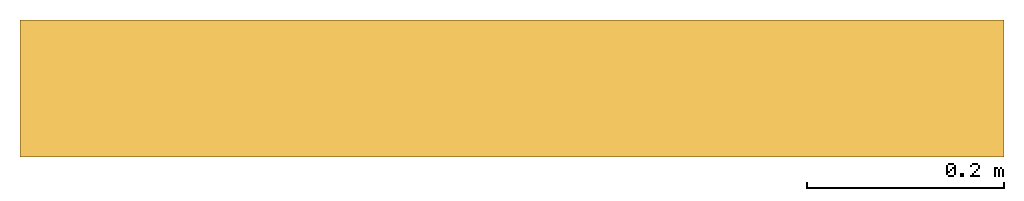
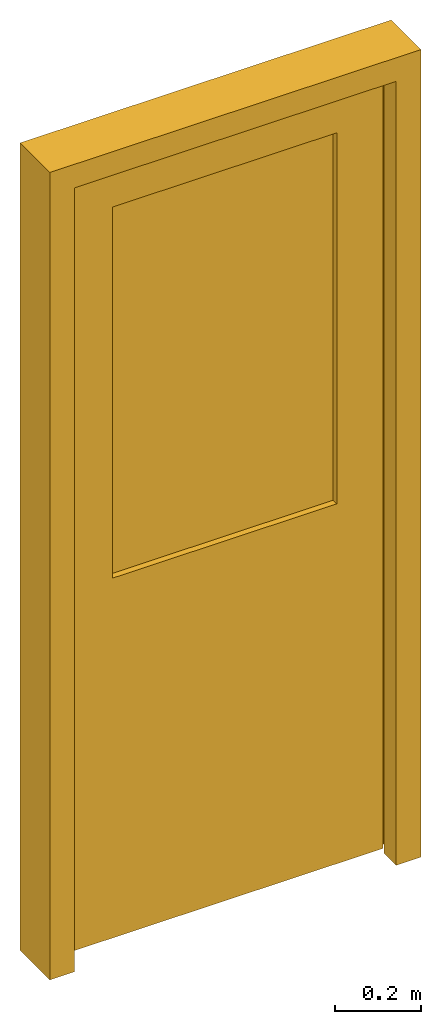
# One storey: 1 door.
"""IFC4 building model written with IfcOpenShell, lengths in millimetres."""

from ifc_helpers import new_model, entity, si_unit, converted_unit, frame, origin_with_axes, origin_2d_with_axis, place, context, subcontext, project, spatial, polygons, source, transform, mapped, type_object, type_shapes, element, save


model = new_model("IFC4")

# Units and contexts
model_context = context("Model", 3, precision=1e-05, world=origin_with_axes())
plan_context = context("Plan", 2, precision=1e-05, world=origin_2d_with_axis())
body_context = subcontext(model_context, "Body", "Model", "MODEL_VIEW")
ifc_project = project(units=[si_unit("VOLUMEUNIT", "CUBIC_METRE"), si_unit("LENGTHUNIT", "METRE", prefix="MILLI"), converted_unit("PLANEANGLEUNIT", "degree", entity("IfcReal", 0.0174532925199433), si_unit("PLANEANGLEUNIT", "RADIAN"), dimensions=[0, 0, 0, 0, 0, 0, 0]), si_unit("AREAUNIT", "SQUARE_METRE")], contexts=[model_context, plan_context])

# Site, building, storey
site_placement = place(None, origin_with_axes())
site = spatial("IfcSite", under=ifc_project, at=site_placement)
building_placement = place(site_placement, origin_with_axes())
building = spatial("IfcBuilding", under=site, at=building_placement, Name="Building")
storey_placement = place(building_placement, origin_with_axes())
storey = spatial("IfcBuildingStorey", under=building, at=storey_placement, Name="Storey")

# Door
door_type = type_object("IfcDoorType", Name="D-1000x2300", OperationType="NOTDEFINED", PredefinedType="DOOR")
shared_shape = source(origin_with_axes(), body_context, "Body", "Tessellation", [
    polygons([(0.0, 5.02680959471036e-05, 2.43237044004682e-13), (1000.00006103516, 5.02680959471036e-05, 2.43237044004682e-13), (0.0, -5.02680959471036e-05, 2300.0), (1000.00006103516, -5.02680959471036e-05, 2300.0), (67.0000305175781, -139.000076293945, 2233.00024414062), (67.0000305175781, -138.999954223633, -6.07588344792021e-06), (933.000061035156, -138.999954223633, -6.07588344792021e-06), (933.000061035156, -139.000076293945, 2233.00024414062), (0.0, -139.000076293945, 2300.0), (0.0, -138.999954223633, -6.07588344792021e-06), (1000.00006103516, -138.999954223633, -6.07588344792021e-06), (1000.00006103516, -139.000076293945, 2300.0), (933.000061035156, -82.0000457763672, 2233.00024414062), (67.0000305175781, -82.0000457763672, 2233.00024414062), (67.0000305175781, -82.0000457763672, -3.58433771907585e-06), (933.000061035156, -82.0000457763672, -3.58433771907585e-06), (49.9999504089355, 4.73394320579246e-05, 1.15221078663373e-13), (49.9999504089355, -82.0000457763672, -3.58433771907585e-06), (67.0000305175781, -4.73394320579246e-05, 2249.99975585938), (67.0000305175781, -82.0000457763672, 2249.99975585938), (49.9999504089355, -82.0000457763672, 2249.99975585938), (49.9999504089355, -4.73394320579246e-05, 2249.99975585938), (950.000061035156, 4.73394320579246e-05, 1.15221078663373e-13), (950.000061035156, -4.73394393338822e-05, 2233.00024414062), (950.000061035156, -82.0000457763672, 2249.99975585938), (950.000061035156, -82.0000457763672, 2233.00024414062), (950.000061035156, -82.0000457763672, -3.58433771907585e-06), (950.000061035156, -4.73394320579246e-05, 2249.99975585938), (198.000015258789, -34.9999504089355, 1045.0), (802.000061035156, -34.9999504089355, 1045.0), (198.000015258789, -35.0000419616699, 2102.0), (802.000061035156, -35.0000419616699, 2102.0), (73.0000228881836, -74.0000457763672, 2227.0), (73.0000228881836, -73.9999465942383, 19.9999752044678), (927.000061035156, -73.9999465942383, 19.9999752044678), (927.000061035156, -74.0000457763672, 2227.0), (56.0000267028809, -74.0000457763672, 2244.0), (56.0000267028809, -73.9999465942383, 19.9999752044678), (944.000061035156, -73.9999465942383, 19.9999752044678), (944.000061035156, -74.0000457763672, 2244.0), (198.000015258789, -89.0000381469727, 2102.0), (198.000015258789, -88.9999542236328, 1045.0), (802.000061035156, -88.9999542236328, 1045.0), (802.000061035156, -89.0000381469727, 2102.0), (56.0000267028809, -35.0000457763672, 2244.0), (56.0000267028809, -34.9999465942383, 19.9999771118164), (944.000061035156, -34.9999465942383, 19.9999771118164), (944.000061035156, -35.0000457763672, 2244.0), (73.0000228881836, -89.0000457763672, 2227.0), (73.0000228881836, -88.9999465942383, 19.9999752044678), (927.000061035156, -88.9999465942383, 19.9999752044678), (927.000061035156, -89.0000457763672, 2227.0), (198.0, -51.9999351501465, 1045.0), (802.000061035156, -51.9999351501465, 1045.0), (198.0, -51.9999656677246, 2102.0), (802.000061035156, -51.9999656677246, 2102.0), (198.0, -71.9999618530273, 2102.0), (198.0, -71.9999313354492, 1045.0), (802.000061035156, -71.9999313354492, 1045.0), (802.000061035156, -71.9999618530273, 2102.0)], [[[6, 5, 8, 7, 11, 12, 9, 10]], [[17, 1, 3, 4, 2, 23, 24, 28, 19, 22]], [[14, 13, 8, 5]], [[15, 6, 10, 1, 17, 18]], [[2, 4, 12, 11]], [[3, 1, 10, 9]], [[6, 15, 14, 5]], [[16, 13, 14, 15, 18, 21, 20, 25, 26, 27]], [[4, 3, 9, 12]], [[23, 2, 11, 7, 16, 27]], [[7, 8, 13, 16]], [[17, 22, 21, 18]], [[19, 28, 25, 20, 21, 22]], [[23, 27, 26, 25, 28, 24]]], closed=True),
    polygons([(0.0, 5.02680959471036e-05, 2.43237044004682e-13), (1000.00006103516, 5.02680959471036e-05, 2.43237044004682e-13), (0.0, -5.02680959471036e-05, 2300.0), (1000.00006103516, -5.02680959471036e-05, 2300.0), (67.0000305175781, -139.000076293945, 2233.00024414062), (67.0000305175781, -138.999954223633, -6.07588344792021e-06), (933.000061035156, -138.999954223633, -6.07588344792021e-06), (933.000061035156, -139.000076293945, 2233.00024414062), (0.0, -139.000076293945, 2300.0), (0.0, -138.999954223633, -6.07588344792021e-06), (1000.00006103516, -138.999954223633, -6.07588344792021e-06), (1000.00006103516, -139.000076293945, 2300.0), (933.000061035156, -82.0000457763672, 2233.00024414062), (67.0000305175781, -82.0000457763672, 2233.00024414062), (67.0000305175781, -82.0000457763672, -3.58433771907585e-06), (933.000061035156, -82.0000457763672, -3.58433771907585e-06), (49.9999504089355, 4.73394320579246e-05, 1.15221078663373e-13), (49.9999504089355, -82.0000457763672, -3.58433771907585e-06), (67.0000305175781, -4.73394320579246e-05, 2249.99975585938), (67.0000305175781, -82.0000457763672, 2249.99975585938), (49.9999504089355, -82.0000457763672, 2249.99975585938), (49.9999504089355, -4.73394320579246e-05, 2249.99975585938), (950.000061035156, 4.73394320579246e-05, 1.15221078663373e-13), (950.000061035156, -4.73394393338822e-05, 2233.00024414062), (950.000061035156, -82.0000457763672, 2249.99975585938), (950.000061035156, -82.0000457763672, 2233.00024414062), (950.000061035156, -82.0000457763672, -3.58433771907585e-06), (950.000061035156, -4.73394320579246e-05, 2249.99975585938), (198.000015258789, -34.9999504089355, 1045.0), (802.000061035156, -34.9999504089355, 1045.0), (198.000015258789, -35.0000419616699, 2102.0), (802.000061035156, -35.0000419616699, 2102.0), (73.0000228881836, -74.0000457763672, 2227.0), (73.0000228881836, -73.9999465942383, 19.9999752044678), (927.000061035156, -73.9999465942383, 19.9999752044678), (927.000061035156, -74.0000457763672, 2227.0), (56.0000267028809, -74.0000457763672, 2244.0), (56.0000267028809, -73.9999465942383, 19.9999752044678), (944.000061035156, -73.9999465942383, 19.9999752044678), (944.000061035156, -74.0000457763672, 2244.0), (198.000015258789, -89.0000381469727, 2102.0), (198.000015258789, -88.9999542236328, 1045.0), (802.000061035156, -88.9999542236328, 1045.0), (802.000061035156, -89.0000381469727, 2102.0), (56.0000267028809, -35.0000457763672, 2244.0), (56.0000267028809, -34.9999465942383, 19.9999771118164), (944.000061035156, -34.9999465942383, 19.9999771118164), (944.000061035156, -35.0000457763672, 2244.0), (73.0000228881836, -89.0000457763672, 2227.0), (73.0000228881836, -88.9999465942383, 19.9999752044678), (927.000061035156, -88.9999465942383, 19.9999752044678), (927.000061035156, -89.0000457763672, 2227.0), (198.0, -51.9999351501465, 1045.0), (802.000061035156, -51.9999351501465, 1045.0), (198.0, -51.9999656677246, 2102.0), (802.000061035156, -51.9999656677246, 2102.0), (198.0, -71.9999618530273, 2102.0), (198.0, -71.9999313354492, 1045.0), (802.000061035156, -71.9999313354492, 1045.0), (802.000061035156, -71.9999618530273, 2102.0)], [[[43, 44, 32, 30]], [[48, 45, 37, 40]], [[47, 48, 40, 39]], [[45, 46, 38, 37]], [[34, 33, 37, 38]], [[36, 35, 39, 40]], [[33, 36, 40, 37]], [[42, 43, 30, 29]], [[35, 36, 52, 51]], [[33, 34, 50, 49]], [[36, 33, 49, 52]], [[46, 47, 39, 35, 51, 50, 34, 38]], [[42, 41, 49, 50, 51, 52, 44, 43]], [[32, 31, 45, 48]], [[41, 44, 52, 49]], [[44, 41, 31, 32]], [[41, 42, 29, 31]], [[31, 29, 30, 32, 48, 47, 46, 45]]], closed=True),
    polygons([(0.0, 5.02680959471036e-05, 2.43237044004682e-13), (1000.00006103516, 5.02680959471036e-05, 2.43237044004682e-13), (0.0, -5.02680959471036e-05, 2300.0), (1000.00006103516, -5.02680959471036e-05, 2300.0), (67.0000305175781, -139.000076293945, 2233.00024414062), (67.0000305175781, -138.999954223633, -6.07588344792021e-06), (933.000061035156, -138.999954223633, -6.07588344792021e-06), (933.000061035156, -139.000076293945, 2233.00024414062), (0.0, -139.000076293945, 2300.0), (0.0, -138.999954223633, -6.07588344792021e-06), (1000.00006103516, -138.999954223633, -6.07588344792021e-06), (1000.00006103516, -139.000076293945, 2300.0), (933.000061035156, -82.0000457763672, 2233.00024414062), (67.0000305175781, -82.0000457763672, 2233.00024414062), (67.0000305175781, -82.0000457763672, -3.58433771907585e-06), (933.000061035156, -82.0000457763672, -3.58433771907585e-06), (49.9999504089355, 4.73394320579246e-05, 1.15221078663373e-13), (49.9999504089355, -82.0000457763672, -3.58433771907585e-06), (67.0000305175781, -4.73394320579246e-05, 2249.99975585938), (67.0000305175781, -82.0000457763672, 2249.99975585938), (49.9999504089355, -82.0000457763672, 2249.99975585938), (49.9999504089355, -4.73394320579246e-05, 2249.99975585938), (950.000061035156, 4.73394320579246e-05, 1.15221078663373e-13), (950.000061035156, -4.73394393338822e-05, 2233.00024414062), (950.000061035156, -82.0000457763672, 2249.99975585938), (950.000061035156, -82.0000457763672, 2233.00024414062), (950.000061035156, -82.0000457763672, -3.58433771907585e-06), (950.000061035156, -4.73394320579246e-05, 2249.99975585938), (198.000015258789, -34.9999504089355, 1045.0), (802.000061035156, -34.9999504089355, 1045.0), (198.000015258789, -35.0000419616699, 2102.0), (802.000061035156, -35.0000419616699, 2102.0), (73.0000228881836, -74.0000457763672, 2227.0), (73.0000228881836, -73.9999465942383, 19.9999752044678), (927.000061035156, -73.9999465942383, 19.9999752044678), (927.000061035156, -74.0000457763672, 2227.0), (56.0000267028809, -74.0000457763672, 2244.0), (56.0000267028809, -73.9999465942383, 19.9999752044678), (944.000061035156, -73.9999465942383, 19.9999752044678), (944.000061035156, -74.0000457763672, 2244.0), (198.000015258789, -89.0000381469727, 2102.0), (198.000015258789, -88.9999542236328, 1045.0), (802.000061035156, -88.9999542236328, 1045.0), (802.000061035156, -89.0000381469727, 2102.0), (56.0000267028809, -35.0000457763672, 2244.0), (56.0000267028809, -34.9999465942383, 19.9999771118164), (944.000061035156, -34.9999465942383, 19.9999771118164), (944.000061035156, -35.0000457763672, 2244.0), (73.0000228881836, -89.0000457763672, 2227.0), (73.0000228881836, -88.9999465942383, 19.9999752044678), (927.000061035156, -88.9999465942383, 19.9999752044678), (927.000061035156, -89.0000457763672, 2227.0), (198.0, -51.9999351501465, 1045.0), (802.000061035156, -51.9999351501465, 1045.0), (198.0, -51.9999656677246, 2102.0), (802.000061035156, -51.9999656677246, 2102.0), (198.0, -71.9999618530273, 2102.0), (198.0, -71.9999313354492, 1045.0), (802.000061035156, -71.9999313354492, 1045.0), (802.000061035156, -71.9999618530273, 2102.0)], [[[53, 55, 56, 54]], [[58, 59, 60, 57]], [[55, 53, 58, 57]], [[56, 55, 57, 60]], [[53, 54, 59, 58]], [[54, 56, 60, 59]]], closed=True),
])
type_shapes(door_type, [shared_shape])
door_placement = place(storey_placement, frame((0.0, 5.21540641784668e-05, 0.0), z_axis=(0.0, 0.0, 1.0), x_axis=(1.0, 0.0, 0.0)))
element("IfcDoor", 1, at=door_placement, inside=storey, type_object=door_type, Name="Door", context=body_context, shape_type="MappedRepresentation", body=[
    mapped(shared_shape, transform((0.0, 0.0, 0.0), x_axis=(1.0, 0.0, 0.0), y_axis=(0.0, 1.0, 0.0), z_axis=(0.0, 0.0, 1.0), scale=1.0)),
])

save(model, "model.ifc")
